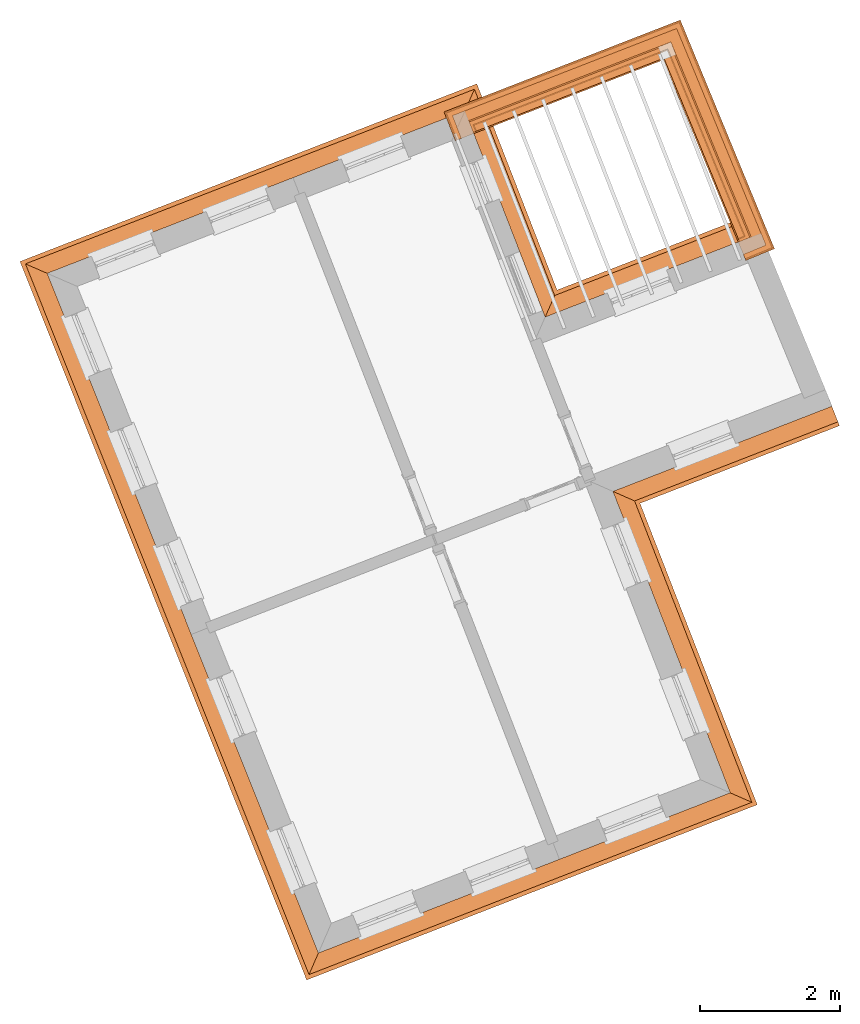
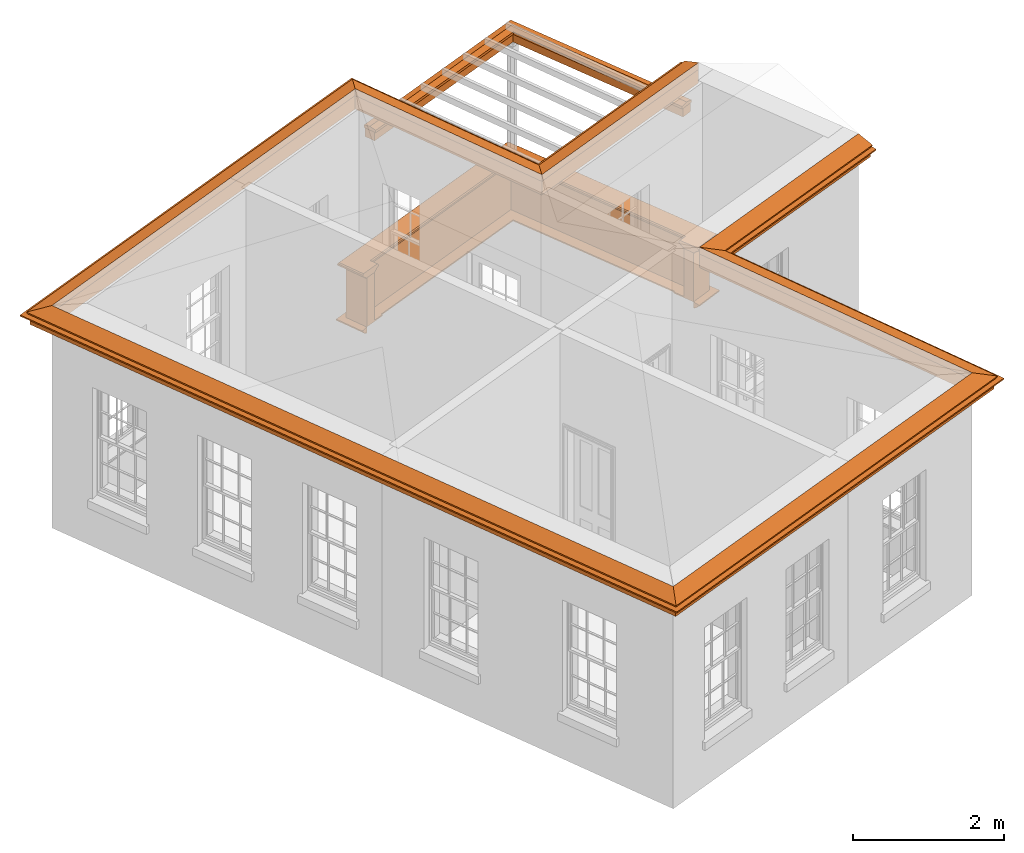
# One storey, part 10 of 11: 7 proxies.
"""IFC2X3 building model written with IfcOpenShell, lengths in metres."""

from ifc_helpers import new_model, entity, si_unit, frame, origin, place, context, subcontext, project, spatial, element, save


model = new_model("IFC2X3")

# Units and contexts
model_context = context("Model", 3, world=origin())
body_context = subcontext(model_context, "Body", "Model", "MODEL_VIEW")
ifc_project = project(units=[si_unit("PLANEANGLEUNIT", "RADIAN"), si_unit("MASSUNIT", "GRAM", prefix="KILO"), si_unit("FORCEUNIT", "NEWTON", prefix="KILO"), si_unit("LENGTHUNIT", "METRE")], contexts=[model_context])

# Site, building, storey
site_placement = place(None, origin())
site = spatial("IfcSite", under=ifc_project, at=site_placement, CompositionType="ELEMENT")
building_placement = place(None, origin())
building = spatial("IfcBuilding", under=site, at=building_placement, Name="Building plot-3", CompositionType="ELEMENT")
storey_placement = place(None, frame((0.0, 0.0, 5.45)))
storey = spatial("IfcBuildingStorey", under=building, at=storey_placement, Name="Floor 1", CompositionType="ELEMENT", Elevation=5.45)

# Proxies
proxy_1_placement = place(storey_placement, frame((0.0, 0.0, 3.6)))
axis2_placement3_d_1 = entity("IfcAxis2Placement3D", entity("IfcCartesianPoint", [0.0, 0.0, 0.0]))
element("IfcBuildingElementProxy", 1, at=proxy_1_placement, inside=storey, Name="eaves", CompositionType="ELEMENT", context=body_context, shape_type="SweptSolid", held_by="IfcProductRepresentation", body=[
    entity("IfcSurfaceCurveSweptAreaSolid", entity("IfcArbitraryClosedProfileDef", "AREA", None, entity("IfcPolyline", [entity("IfcCartesianPoint", [-0.11, 0.25]), entity("IfcCartesianPoint", [-0.33, 0.25]), entity("IfcCartesianPoint", [-0.33, 0.265]), entity("IfcCartesianPoint", [-0.318, 0.268]), entity("IfcCartesianPoint", [-0.309, 0.274]), entity("IfcCartesianPoint", [-0.303, 0.283]), entity("IfcCartesianPoint", [-0.3, 0.295]), entity("IfcCartesianPoint", [-0.285, 0.295]), entity("IfcCartesianPoint", [-0.285, 0.455]), entity("IfcCartesianPoint", [-0.205, 0.455]), entity("IfcCartesianPoint", [-0.205, 0.47]), entity("IfcCartesianPoint", [-0.19, 0.47]), entity("IfcCartesianPoint", [-0.189, 0.483]), entity("IfcCartesianPoint", [-0.186, 0.494]), entity("IfcCartesianPoint", [-0.179, 0.506]), entity("IfcCartesianPoint", [-0.17, 0.514]), entity("IfcCartesianPoint", [-0.16, 0.52]), entity("IfcCartesianPoint", [-0.149, 0.529]), entity("IfcCartesianPoint", [-0.143, 0.539]), entity("IfcCartesianPoint", [-0.14, 0.55]), entity("IfcCartesianPoint", [-0.12, 0.55]), entity("IfcCartesianPoint", [-0.11, 0.48]), entity("IfcCartesianPoint", [-0.11, 0.25])])), axis2_placement3_d_1, entity("IfcPolyline", [entity("IfcCartesianPoint", [43.8114863275859, 51.6157090759188]), entity("IfcCartesianPoint", [40.4799183958, 50.3196691667558]), entity("IfcCartesianPoint", [39.3294303409562, 53.2770851246455]), entity("IfcCartesianPoint", [33.8099475072922, 51.1299069260206]), entity("IfcCartesianPoint", [37.5118617490977, 41.850970024341]), entity("IfcCartesianPoint", [42.9512282634885, 43.9669815323027]), entity("IfcCartesianPoint", [41.270311618924, 48.2879040204481]), entity("IfcCartesianPoint", [44.642081391258, 49.5995831694042])]), 0.0, 1.0, entity("IfcPlane", axis2_placement3_d_1)),
])
proxy_2_placement = place(storey_placement, frame((0.0, 0.0, 3.6)))
axis2_placement3_d_2 = entity("IfcAxis2Placement3D", entity("IfcCartesianPoint", [0.0, 0.0, 0.0]))
element("IfcBuildingElementProxy", 2, at=proxy_2_placement, inside=storey, Name="eaves", CompositionType="ELEMENT", context=body_context, shape_type="SweptSolid", held_by="IfcProductRepresentation", body=[
    entity("IfcSurfaceCurveSweptAreaSolid", entity("IfcArbitraryClosedProfileDef", "AREA", None, entity("IfcPolyline", [entity("IfcCartesianPoint", [-0.11, 0.25]), entity("IfcCartesianPoint", [-0.11, 0.48]), entity("IfcCartesianPoint", [-0.08, 0.49]), entity("IfcCartesianPoint", [0.0, 0.25]), entity("IfcCartesianPoint", [-0.11, 0.25])])), axis2_placement3_d_2, entity("IfcPolyline", [entity("IfcCartesianPoint", [43.8114863275859, 51.6157090759188]), entity("IfcCartesianPoint", [40.4799183958, 50.3196691667558]), entity("IfcCartesianPoint", [39.3294303409562, 53.2770851246455]), entity("IfcCartesianPoint", [33.8099475072922, 51.1299069260206]), entity("IfcCartesianPoint", [37.5118617490977, 41.850970024341]), entity("IfcCartesianPoint", [42.9512282634885, 43.9669815323027]), entity("IfcCartesianPoint", [41.270311618924, 48.2879040204481]), entity("IfcCartesianPoint", [44.642081391258, 49.5995831694042])]), 0.0, 1.0, entity("IfcPlane", axis2_placement3_d_2)),
])
proxy_3_placement = place(storey_placement, origin())
axis2_placement3_d_3 = entity("IfcAxis2Placement3D", entity("IfcCartesianPoint", [0.0, 0.0, 0.0]))
element("IfcBuildingElementProxy", 3, at=proxy_3_placement, inside=storey, Name="parapet", CompositionType="ELEMENT", context=body_context, shape_type="SweptSolid", held_by="IfcProductRepresentation", body=[
    entity("IfcSurfaceCurveSweptAreaSolid", entity("IfcArbitraryClosedProfileDef", "AREA", None, entity("IfcPolyline", [entity("IfcCartesianPoint", [0.0, 0.25]), entity("IfcCartesianPoint", [0.795, 0.25]), entity("IfcCartesianPoint", [0.795, 0.09]), entity("IfcCartesianPoint", [0.02, 0.09]), entity("IfcCartesianPoint", [0.02, -0.08]), entity("IfcCartesianPoint", [0.0, -0.08]), entity("IfcCartesianPoint", [0.0, 0.25])])), axis2_placement3_d_3, entity("IfcPolyline", [entity("IfcCartesianPoint", [43.3679502167663, 51.7736086172604]), entity("IfcCartesianPoint", [43.4604111537161, 51.8117002848317]), entity("IfcCartesianPoint", [42.3694898924601, 54.4597230253738]), entity("IfcCartesianPoint", [39.6183391864104, 53.3894758672284]), entity("IfcCartesianPoint", [39.6545942646629, 53.296279465469])]), 0.0, 1.0, entity("IfcPlane", axis2_placement3_d_3)),
])
proxy_4_placement = place(storey_placement, origin())
axis2_placement3_d_4 = entity("IfcAxis2Placement3D", entity("IfcCartesianPoint", [0.0, 0.0, 0.0]))
element("IfcBuildingElementProxy", 4, at=proxy_4_placement, inside=storey, Name="parapet", CompositionType="ELEMENT", context=body_context, shape_type="SweptSolid", held_by="IfcProductRepresentation", body=[
    entity("IfcSurfaceCurveSweptAreaSolid", entity("IfcArbitraryClosedProfileDef", "AREA", None, entity("IfcPolyline", [entity("IfcCartesianPoint", [0.795, 0.265]), entity("IfcCartesianPoint", [0.807, 0.268]), entity("IfcCartesianPoint", [0.816, 0.274]), entity("IfcCartesianPoint", [0.822, 0.283]), entity("IfcCartesianPoint", [0.825, 0.295]), entity("IfcCartesianPoint", [0.84, 0.295]), entity("IfcCartesianPoint", [0.84, 0.305]), entity("IfcCartesianPoint", [0.842, 0.317]), entity("IfcCartesianPoint", [0.849, 0.326]), entity("IfcCartesianPoint", [0.858, 0.333]), entity("IfcCartesianPoint", [0.87, 0.335]), entity("IfcCartesianPoint", [0.882, 0.333]), entity("IfcCartesianPoint", [0.891, 0.326]), entity("IfcCartesianPoint", [0.898, 0.317]), entity("IfcCartesianPoint", [0.9, 0.305]), entity("IfcCartesianPoint", [0.9, 0.035]), entity("IfcCartesianPoint", [0.898, 0.023]), entity("IfcCartesianPoint", [0.891, 0.014]), entity("IfcCartesianPoint", [0.882, 0.007]), entity("IfcCartesianPoint", [0.87, 0.005]), entity("IfcCartesianPoint", [0.858, 0.007]), entity("IfcCartesianPoint", [0.849, 0.014]), entity("IfcCartesianPoint", [0.842, 0.023]), entity("IfcCartesianPoint", [0.84, 0.035]), entity("IfcCartesianPoint", [0.84, 0.045]), entity("IfcCartesianPoint", [0.825, 0.045]), entity("IfcCartesianPoint", [0.822, 0.057]), entity("IfcCartesianPoint", [0.816, 0.066]), entity("IfcCartesianPoint", [0.807, 0.072]), entity("IfcCartesianPoint", [0.795, 0.075]), entity("IfcCartesianPoint", [0.795, 0.265])])), axis2_placement3_d_4, entity("IfcPolyline", [entity("IfcCartesianPoint", [43.3679502167663, 51.7736086172604]), entity("IfcCartesianPoint", [43.4604111537161, 51.8117002848317]), entity("IfcCartesianPoint", [42.3694898924601, 54.4597230253738]), entity("IfcCartesianPoint", [39.6183391864104, 53.3894758672284]), entity("IfcCartesianPoint", [39.6545942646629, 53.296279465469])]), 0.0, 1.0, entity("IfcPlane", axis2_placement3_d_4)),
])
proxy_5_placement = place(storey_placement, origin())
axis2_placement3_d_5 = entity("IfcAxis2Placement3D", entity("IfcCartesianPoint", [0.0, 0.0, 0.0]))
element("IfcBuildingElementProxy", 5, at=proxy_5_placement, inside=storey, Name="parapet", CompositionType="ELEMENT", context=body_context, shape_type="SweptSolid", held_by="IfcProductRepresentation", body=[
    entity("IfcSurfaceCurveSweptAreaSolid", entity("IfcArbitraryClosedProfileDef", "AREA", None, entity("IfcPolyline", [entity("IfcCartesianPoint", [-0.1, 0.25]), entity("IfcCartesianPoint", [-0.1, 0.265]), entity("IfcCartesianPoint", [-0.085, 0.265]), entity("IfcCartesianPoint", [-0.084, 0.278]), entity("IfcCartesianPoint", [-0.081, 0.289]), entity("IfcCartesianPoint", [-0.074, 0.301]), entity("IfcCartesianPoint", [-0.065, 0.309]), entity("IfcCartesianPoint", [-0.055, 0.315]), entity("IfcCartesianPoint", [-0.044, 0.324]), entity("IfcCartesianPoint", [-0.038, 0.334]), entity("IfcCartesianPoint", [-0.035, 0.345]), entity("IfcCartesianPoint", [-0.015, 0.345]), entity("IfcCartesianPoint", [0.0, 0.25]), entity("IfcCartesianPoint", [-0.1, 0.25])])), axis2_placement3_d_5, entity("IfcPolyline", [entity("IfcCartesianPoint", [43.3679502167663, 51.7736086172604]), entity("IfcCartesianPoint", [43.4604111537161, 51.8117002848317]), entity("IfcCartesianPoint", [42.3694898924601, 54.4597230253738]), entity("IfcCartesianPoint", [39.6183391864104, 53.3894758672284]), entity("IfcCartesianPoint", [39.6545942646629, 53.296279465469])]), 0.0, 1.0, entity("IfcPlane", axis2_placement3_d_5)),
])
proxy_6_placement = place(storey_placement, frame((0.0, 0.0, 3.6)))
axis2_placement3_d_6 = entity("IfcAxis2Placement3D", entity("IfcCartesianPoint", [0.0, 0.0, 0.0]))
element("IfcBuildingElementProxy", 6, at=proxy_6_placement, inside=storey, Name="pergola beam", CompositionType="ELEMENT", context=body_context, shape_type="SweptSolid", held_by="IfcProductRepresentation", body=[
    entity("IfcSurfaceCurveSweptAreaSolid", entity("IfcArbitraryClosedProfileDef", "AREA", None, entity("IfcPolyline", [entity("IfcCartesianPoint", [-0.7, -0.08]), entity("IfcCartesianPoint", [-0.7, 0.08]), entity("IfcCartesianPoint", [-0.56, 0.08]), entity("IfcCartesianPoint", [-0.56, -0.08]), entity("IfcCartesianPoint", [-0.7, -0.08])])), axis2_placement3_d_6, entity("IfcPolyline", [entity("IfcCartesianPoint", [43.483266154259, 51.7562237226619]), entity("IfcCartesianPoint", [42.3694898924601, 54.4597230253738]), entity("IfcCartesianPoint", [39.5624213453547, 53.3677228202769])]), 0.0, 1.0, entity("IfcPlane", axis2_placement3_d_6)),
])
proxy_7_placement = place(storey_placement, frame((0.0, 0.0, 3.6)))
axis2_placement3_d_7 = entity("IfcAxis2Placement3D", entity("IfcCartesianPoint", [0.0, 0.0, 0.0]))
element("IfcBuildingElementProxy", 7, at=proxy_7_placement, inside=storey, Name="pergola beam", CompositionType="ELEMENT", context=body_context, shape_type="SweptSolid", held_by="IfcProductRepresentation", body=[
    entity("IfcSurfaceCurveSweptAreaSolid", entity("IfcArbitraryClosedProfileDef", "AREA", None, entity("IfcPolyline", [entity("IfcCartesianPoint", [-0.5, 0.0]), entity("IfcCartesianPoint", [-0.52, -0.1]), entity("IfcCartesianPoint", [-0.56, -0.1]), entity("IfcCartesianPoint", [-0.56, 0.1]), entity("IfcCartesianPoint", [-0.52, 0.1]), entity("IfcCartesianPoint", [-0.5, 0.0])])), axis2_placement3_d_7, entity("IfcPolyline", [entity("IfcCartesianPoint", [43.483266154259, 51.7562237226619]), entity("IfcCartesianPoint", [42.3694898924601, 54.4597230253738]), entity("IfcCartesianPoint", [39.5624213453547, 53.3677228202769])]), 0.0, 1.0, entity("IfcPlane", axis2_placement3_d_7)),
])

save(model, "model.ifc")
